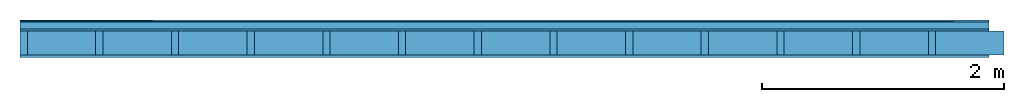
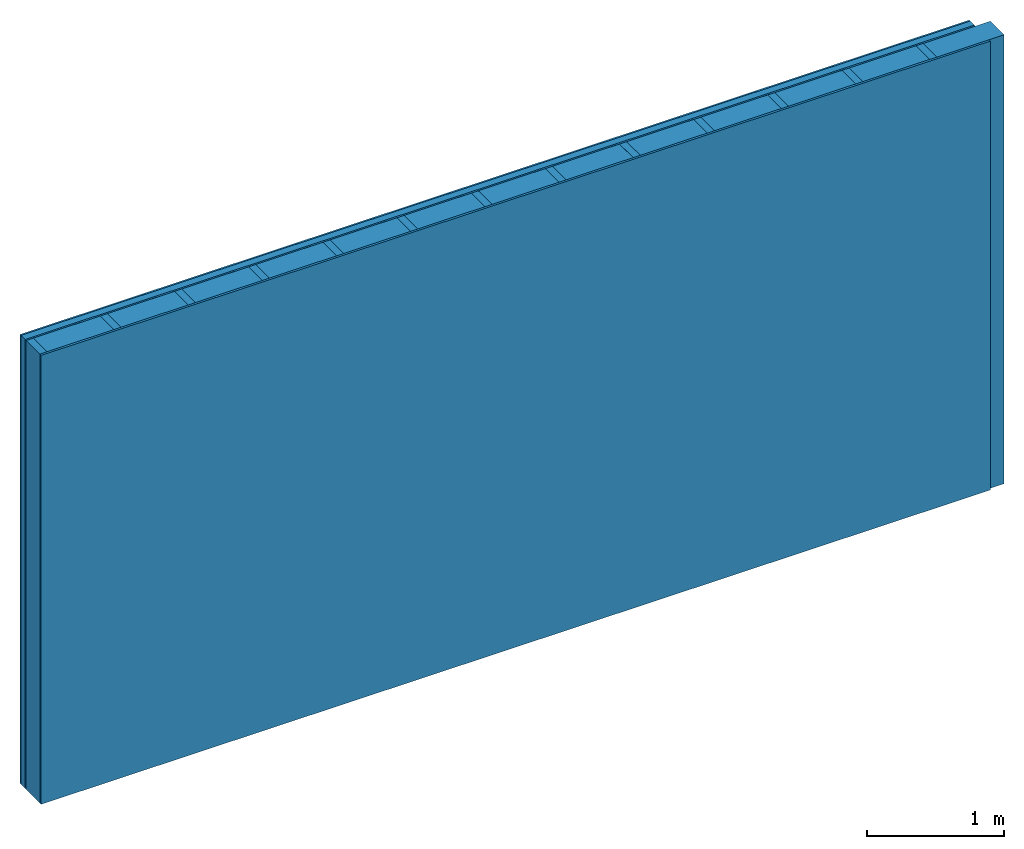
# One storey: 4 plates, 2 members, 1 element without a shape of its own.
"""IFC4 building model written with IfcOpenShell, lengths in metres."""

from ifc_helpers import new_model, si_unit, derived_unit, direction, frame, frame_2d, origin, origin_with_axes, place, context, project, spatial, rectangle, extrude, material, layer, layer_set, type_object, element, aggregate, save


model = new_model("IFC4")

# Units and contexts
plan_context = context("Plan", 3, precision=1e-05, world=origin(), true_north=direction((0.0, 1.0)))
model_context = context("Model", 3, precision=1e-05, world=origin(), true_north=direction((0.0, 1.0)))
ifc_project = project(units=[si_unit("LENGTHUNIT", "METRE"), derived_unit("SOUNDPRESSUREUNIT", [(si_unit("PRESSUREUNIT", "PASCAL", prefix="MICRO"), 0)]), si_unit("ENERGYUNIT", "JOULE", prefix="MEGA"), si_unit("MASSUNIT", "GRAM", prefix="KILO"), derived_unit("THERMALTRANSMITTANCEUNIT", [(si_unit("POWERUNIT", "WATT"), 1), (si_unit("AREAUNIT", "SQUARE_METRE"), -1), (si_unit("THERMODYNAMICTEMPERATUREUNIT", "KELVIN"), -1)]), derived_unit("AREADENSITYUNIT", [(si_unit("MASSUNIT", "GRAM", prefix="KILO"), 1), (si_unit("AREAUNIT", "SQUARE_METRE"), -1)]), derived_unit("USERDEFINED", [(si_unit("ENERGYUNIT", "JOULE", prefix="MEGA"), 1), (si_unit("AREAUNIT", "SQUARE_METRE"), -1)])], contexts=[plan_context, model_context])

# Site, building, storey
site = spatial("IfcSite", under=ifc_project)
building_placement = place(None, origin())
building = spatial("IfcBuilding", under=site, at=building_placement)
storey_placement = place(building_placement, origin())
storey = spatial("IfcBuildingStorey", under=building, at=storey_placement)

# Wall, members, plates
ifc_material_1 = material(Category="04.011")
ifc_layer_1 = layer(ifc_material_1, 0.015, Name="Surface 1")
ifc_material_2 = material(Category="10.009")
ifc_layer_2 = layer(ifc_material_2, 0.06, Name="outside 2nd layer")
ifc_material_3 = material(Category="03.007")
ifc_layer_3 = layer(ifc_material_3, 0.015, Name="outside 1st layer")
ifc_material_4 = material(Name="of the art")
ifc_layer_4 = layer(ifc_material_4, 0.0, Name="Bond")
ifc_layer_5 = layer(None, 0.2, Name="Support")
ifc_layer_6 = layer(ifc_material_4, 0.0, Name="Bond")
ifc_material_5 = material(Category="07.013")
ifc_layer_7 = layer(ifc_material_5, 0.019, Name="1st layer")
ifc_layer_set = layer_set([ifc_layer_1, ifc_layer_2, ifc_layer_3, ifc_layer_4, ifc_layer_5, ifc_layer_6, ifc_layer_7])
wall_type = type_object("IfcWallType", Name="D0464", PredefinedType="NOTDEFINED", material=ifc_layer_set)
wall_placement = place(None, frame((0.0, 0.0, 0.0), z_axis=(0.0, -1.0, 0.0), x_axis=(1.0, 0.0, 0.0)))
wall = element("IfcWall", 1, at=wall_placement, inside=storey, type_object=wall_type, material=ifc_layer_set, Name="Wall #1")
ifc_material_6 = material()
member_1_placement = place(wall_placement, origin())
member_1 = element("IfcMember", 2, at=member_1_placement, material=ifc_material_6, Name="Support", context=plan_context, shape_type="SweptSolid", body=[
    extrude(rectangle(XDim=0.06, YDim=0.2, at=frame_2d((0.03, 0.1), x_axis=(1.0, 0.0))), frame((0.0, 4.0, 0.09), z_axis=(0.0, -1.0, 0.0), x_axis=(1.0, 0.0, 0.0)), (0.0, 0.0, 1.0), 4.0),
    extrude(rectangle(XDim=0.06, YDim=0.2, at=frame_2d((0.03, 0.1), x_axis=(1.0, 0.0))), frame((0.625, 4.0, 0.09), z_axis=(0.0, -1.0, 0.0), x_axis=(1.0, 0.0, 0.0)), (0.0, 0.0, 1.0), 4.0),
    extrude(rectangle(XDim=0.06, YDim=0.2, at=frame_2d((0.03, 0.1), x_axis=(1.0, 0.0))), frame((1.25, 4.0, 0.09), z_axis=(0.0, -1.0, 0.0), x_axis=(1.0, 0.0, 0.0)), (0.0, 0.0, 1.0), 4.0),
    extrude(rectangle(XDim=0.06, YDim=0.2, at=frame_2d((0.03, 0.1), x_axis=(1.0, 0.0))), frame((1.875, 4.0, 0.09), z_axis=(0.0, -1.0, 0.0), x_axis=(1.0, 0.0, 0.0)), (0.0, 0.0, 1.0), 4.0),
    extrude(rectangle(XDim=0.06, YDim=0.2, at=frame_2d((0.03, 0.1), x_axis=(1.0, 0.0))), frame((2.5, 4.0, 0.09), z_axis=(0.0, -1.0, 0.0), x_axis=(1.0, 0.0, 0.0)), (0.0, 0.0, 1.0), 4.0),
    extrude(rectangle(XDim=0.06, YDim=0.2, at=frame_2d((0.03, 0.1), x_axis=(1.0, 0.0))), frame((3.125, 4.0, 0.09), z_axis=(0.0, -1.0, 0.0), x_axis=(1.0, 0.0, 0.0)), (0.0, 0.0, 1.0), 4.0),
    extrude(rectangle(XDim=0.06, YDim=0.2, at=frame_2d((0.03, 0.1), x_axis=(1.0, 0.0))), frame((3.75, 4.0, 0.09), z_axis=(0.0, -1.0, 0.0), x_axis=(1.0, 0.0, 0.0)), (0.0, 0.0, 1.0), 4.0),
    extrude(rectangle(XDim=0.06, YDim=0.2, at=frame_2d((0.03, 0.1), x_axis=(1.0, 0.0))), frame((4.375, 4.0, 0.09), z_axis=(0.0, -1.0, 0.0), x_axis=(1.0, 0.0, 0.0)), (0.0, 0.0, 1.0), 4.0),
    extrude(rectangle(XDim=0.06, YDim=0.2, at=frame_2d((0.03, 0.1), x_axis=(1.0, 0.0))), frame((5.0, 4.0, 0.09), z_axis=(0.0, -1.0, 0.0), x_axis=(1.0, 0.0, 0.0)), (0.0, 0.0, 1.0), 4.0),
    extrude(rectangle(XDim=0.06, YDim=0.2, at=frame_2d((0.03, 0.1), x_axis=(1.0, 0.0))), frame((5.625, 4.0, 0.09), z_axis=(0.0, -1.0, 0.0), x_axis=(1.0, 0.0, 0.0)), (0.0, 0.0, 1.0), 4.0),
    extrude(rectangle(XDim=0.06, YDim=0.2, at=frame_2d((0.03, 0.1), x_axis=(1.0, 0.0))), frame((6.25, 4.0, 0.09), z_axis=(0.0, -1.0, 0.0), x_axis=(1.0, 0.0, 0.0)), (0.0, 0.0, 1.0), 4.0),
    extrude(rectangle(XDim=0.06, YDim=0.2, at=frame_2d((0.03, 0.1), x_axis=(1.0, 0.0))), frame((6.875, 4.0, 0.09), z_axis=(0.0, -1.0, 0.0), x_axis=(1.0, 0.0, 0.0)), (0.0, 0.0, 1.0), 4.0),
    extrude(rectangle(XDim=0.06, YDim=0.2, at=frame_2d((0.03, 0.1), x_axis=(1.0, 0.0))), frame((7.5, 4.0, 0.09), z_axis=(0.0, -1.0, 0.0), x_axis=(1.0, 0.0, 0.0)), (0.0, 0.0, 1.0), 4.0),
])
ifc_material_7 = material()
member_2_placement = place(wall_placement, origin())
member_2 = element("IfcMember", 3, at=member_2_placement, material=ifc_material_7, Name="Cavity", context=plan_context, shape_type="SweptSolid", body=[
    extrude(rectangle(XDim=0.565, YDim=0.2, at=frame_2d((0.2825, 0.1), x_axis=(1.0, 0.0))), frame((0.06, 4.0, 0.09), z_axis=(0.0, -1.0, 0.0), x_axis=(1.0, 0.0, 0.0)), (0.0, 0.0, 1.0), 4.0),
    extrude(rectangle(XDim=0.565, YDim=0.2, at=frame_2d((0.2825, 0.1), x_axis=(1.0, 0.0))), frame((0.685, 4.0, 0.09), z_axis=(0.0, -1.0, 0.0), x_axis=(1.0, 0.0, 0.0)), (0.0, 0.0, 1.0), 4.0),
    extrude(rectangle(XDim=0.565, YDim=0.2, at=frame_2d((0.2825, 0.1), x_axis=(1.0, 0.0))), frame((1.31, 4.0, 0.09), z_axis=(0.0, -1.0, 0.0), x_axis=(1.0, 0.0, 0.0)), (0.0, 0.0, 1.0), 4.0),
    extrude(rectangle(XDim=0.565, YDim=0.2, at=frame_2d((0.2825, 0.1), x_axis=(1.0, 0.0))), frame((1.935, 4.0, 0.09), z_axis=(0.0, -1.0, 0.0), x_axis=(1.0, 0.0, 0.0)), (0.0, 0.0, 1.0), 4.0),
    extrude(rectangle(XDim=0.565, YDim=0.2, at=frame_2d((0.2825, 0.1), x_axis=(1.0, 0.0))), frame((2.56, 4.0, 0.09), z_axis=(0.0, -1.0, 0.0), x_axis=(1.0, 0.0, 0.0)), (0.0, 0.0, 1.0), 4.0),
    extrude(rectangle(XDim=0.565, YDim=0.2, at=frame_2d((0.2825, 0.1), x_axis=(1.0, 0.0))), frame((3.185, 4.0, 0.09), z_axis=(0.0, -1.0, 0.0), x_axis=(1.0, 0.0, 0.0)), (0.0, 0.0, 1.0), 4.0),
    extrude(rectangle(XDim=0.565, YDim=0.2, at=frame_2d((0.2825, 0.1), x_axis=(1.0, 0.0))), frame((3.81, 4.0, 0.09), z_axis=(0.0, -1.0, 0.0), x_axis=(1.0, 0.0, 0.0)), (0.0, 0.0, 1.0), 4.0),
    extrude(rectangle(XDim=0.565, YDim=0.2, at=frame_2d((0.2825, 0.1), x_axis=(1.0, 0.0))), frame((4.435, 4.0, 0.09), z_axis=(0.0, -1.0, 0.0), x_axis=(1.0, 0.0, 0.0)), (0.0, 0.0, 1.0), 4.0),
    extrude(rectangle(XDim=0.565, YDim=0.2, at=frame_2d((0.2825, 0.1), x_axis=(1.0, 0.0))), frame((5.06, 4.0, 0.09), z_axis=(0.0, -1.0, 0.0), x_axis=(1.0, 0.0, 0.0)), (0.0, 0.0, 1.0), 4.0),
    extrude(rectangle(XDim=0.565, YDim=0.2, at=frame_2d((0.2825, 0.1), x_axis=(1.0, 0.0))), frame((5.685, 4.0, 0.09), z_axis=(0.0, -1.0, 0.0), x_axis=(1.0, 0.0, 0.0)), (0.0, 0.0, 1.0), 4.0),
    extrude(rectangle(XDim=0.565, YDim=0.2, at=frame_2d((0.2825, 0.1), x_axis=(1.0, 0.0))), frame((6.31, 4.0, 0.09), z_axis=(0.0, -1.0, 0.0), x_axis=(1.0, 0.0, 0.0)), (0.0, 0.0, 1.0), 4.0),
    extrude(rectangle(XDim=0.565, YDim=0.2, at=frame_2d((0.2825, 0.1), x_axis=(1.0, 0.0))), frame((6.935, 4.0, 0.09), z_axis=(0.0, -1.0, 0.0), x_axis=(1.0, 0.0, 0.0)), (0.0, 0.0, 1.0), 4.0),
    extrude(rectangle(XDim=0.565, YDim=0.2, at=frame_2d((0.2825, 0.1), x_axis=(1.0, 0.0))), frame((7.56, 4.0, 0.09), z_axis=(0.0, -1.0, 0.0), x_axis=(1.0, 0.0, 0.0)), (0.0, 0.0, 1.0), 4.0),
])
plate_1_placement = place(wall_placement, origin())
plate_1 = element("IfcPlate", 4, at=plate_1_placement, material=ifc_material_1, Name="Surface 1", context=plan_context, shape_type="SweptSolid", body=[
    extrude(rectangle(XDim=8.0, YDim=4.0, at=frame_2d((4.0, 2.0), x_axis=(1.0, 0.0))), origin_with_axes(), (0.0, 0.0, 1.0), 0.015),
])
plate_2_placement = place(wall_placement, origin())
plate_2 = element("IfcPlate", 5, at=plate_2_placement, material=ifc_material_2, Name="outside 2nd layer", context=plan_context, shape_type="SweptSolid", body=[
    extrude(rectangle(XDim=8.0, YDim=4.0, at=frame_2d((4.0, 2.0), x_axis=(1.0, 0.0))), frame((0.0, 0.0, 0.015), z_axis=(0.0, 0.0, 1.0), x_axis=(1.0, 0.0, 0.0)), (0.0, 0.0, 1.0), 0.06),
])
plate_3_placement = place(wall_placement, origin())
plate_3 = element("IfcPlate", 6, at=plate_3_placement, material=ifc_material_3, Name="outside 1st layer", context=plan_context, shape_type="SweptSolid", body=[
    extrude(rectangle(XDim=8.0, YDim=4.0, at=frame_2d((4.0, 2.0), x_axis=(1.0, 0.0))), frame((0.0, 0.0, 0.075), z_axis=(0.0, 0.0, 1.0), x_axis=(1.0, 0.0, 0.0)), (0.0, 0.0, 1.0), 0.015),
])
plate_4_placement = place(wall_placement, origin())
plate_4 = element("IfcPlate", 7, at=plate_4_placement, material=ifc_material_5, Name="1st layer", context=plan_context, shape_type="SweptSolid", body=[
    extrude(rectangle(XDim=8.0, YDim=4.0, at=frame_2d((4.0, 2.0), x_axis=(1.0, 0.0))), frame((0.0, 0.0, 0.29), z_axis=(0.0, 0.0, 1.0), x_axis=(1.0, 0.0, 0.0)), (0.0, 0.0, 1.0), 0.019),
])
aggregate(wall, [plate_1, plate_2, plate_3, member_1, member_2, plate_4])

save(model, "model.ifc")
